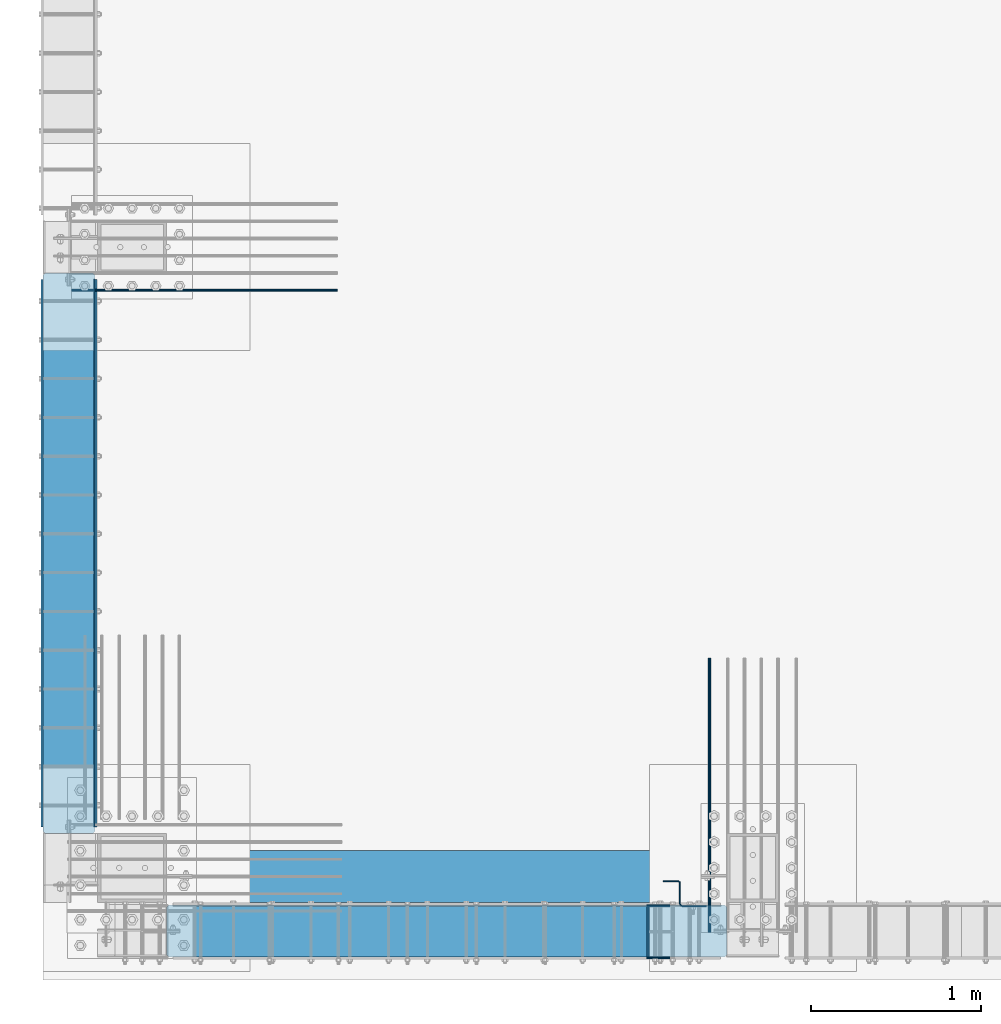
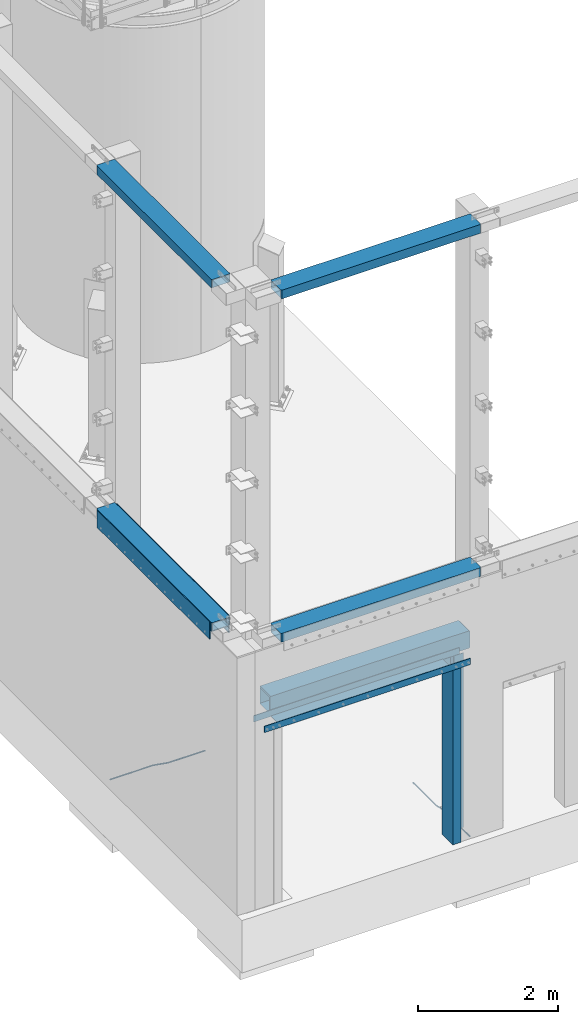
# One storey, part 908 of 1876: 14 beams, 12 elements without a shape of their own.
"""IFC2X3 building model written with IfcOpenShell, lengths in millimetres."""

from ifc_helpers import new_model, si_unit, frame, origin_with_axes, place, context, subcontext, project, spatial, faceted_brep, material, type_object, element, aggregate, save


model = new_model("IFC2X3")

# Units and contexts
model_context = context("Model", 3, precision=1e-05, world=origin_with_axes())
body_context = subcontext(model_context, "Body", "Model", "MODEL_VIEW")
ifc_project = project(units=[si_unit("LENGTHUNIT", "METRE", prefix="MILLI"), si_unit("AREAUNIT", "SQUARE_METRE"), si_unit("VOLUMEUNIT", "CUBIC_METRE"), si_unit("MASSUNIT", "GRAM", prefix="KILO"), si_unit("TIMEUNIT", "SECOND"), si_unit("PLANEANGLEUNIT", "RADIAN"), si_unit("SOLIDANGLEUNIT", "STERADIAN"), si_unit("THERMODYNAMICTEMPERATUREUNIT", "DEGREE_CELSIUS"), si_unit("LUMINOUSINTENSITYUNIT", "LUMEN")], contexts=[model_context])

# Site, building, storey
site_placement = place(None, origin_with_axes())
site = spatial("IfcSite", under=ifc_project, at=site_placement, CompositionType="ELEMENT")
building_placement = place(site_placement, origin_with_axes())
building = spatial("IfcBuilding", under=site, at=building_placement, Name="Undefined", CompositionType="ELEMENT")
storey_placement = place(building_placement, origin_with_axes())
storey = spatial("IfcBuildingStorey", under=building, at=storey_placement, Name="Undefined", CompositionType="ELEMENT", Elevation=0.0)

# Assembly, beam
assembly_1_placement = place(storey_placement, origin_with_axes())
assembly_1 = element("IfcElementAssembly", 1, at=assembly_1_placement, inside=storey, Name="BEAM", AssemblyPlace="NOTDEFINED", PredefinedType="RIGID_FRAME")
ifc_material_1 = material()
beam_type_1 = type_object("IfcBeamType", Name="HSS12X6X1/2", PredefinedType="NOTDEFINED")
beam_1_placement = place(assembly_1_placement, frame((434.974999999999, -25771.475, 10591.8), z_axis=(0.0, 1.0, 0.0), x_axis=(1.0, 0.0, 0.0)))
beam_1 = element("IfcBeam", 2, at=beam_1_placement, type_object=beam_type_1, material=ifc_material_1, Name="BEAM", ObjectType="HSS12X6X1/2", context=body_context, shape_type="Brep", body=[
    faceted_brep([(0.0, -63.5, -139.7), (0.0, -76.2000000000007, -139.699999999812), (0.0, -76.2000000000007, 139.700000000026), (0.0, -63.5, 139.7), (3289.3, 76.2000000000007, -152.400000000001), (3289.3, -76.2000000000007, -152.400000000001), (12.7000000000025, -76.2000000000007, -152.4), (12.7000000000025, 76.2000000000007, -152.4), (3302.0, 63.5, -139.700000000001), (3302.0, 76.2000000000007, -139.700000000004), (3302.0, 76.2000000000007, 139.700000000004), (3302.0, 63.5, 139.700000000001), (3302.0, -63.5, -139.700000000001), (0.0, 63.5, -139.7), (3302.0, -76.2000000000007, -139.700000000004), (3302.0, -76.2000000000007, 139.700000000004), (3289.3, -76.2000000000007, 152.400000000001), (12.6999999999734, -76.2000000000007, 152.4), (0.0, 63.5, 139.7), (12.6999999999734, 76.2000000000007, 152.4), (3302.0, -63.5, 139.700000000001), (3289.3, 76.2000000000007, 152.400000000001)], [[[0, 1, 2, 3]], [[4, 5, 6, 7]], [[8, 9, 10, 11]], [[12, 8, 13, 0]], [[4, 9, 8, 12, 14, 5]], [[1, 6, 5, 14, 15, 16, 17, 2]], [[0, 13, 7, 6, 1]], [[7, 13, 18, 19]], [[8, 11, 18, 13]], [[11, 20, 3, 18]], [[0, 3, 20, 12]], [[14, 12, 20, 15]], [[11, 10, 21, 16, 15, 20]], [[9, 4, 7, 19, 21, 10]], [[16, 21, 19, 17]], [[18, 3, 2, 17, 19]]]),
])
aggregate(assembly_1, [beam_1])

assembly_2_placement = place(storey_placement, origin_with_axes())
assembly_2 = element("IfcElementAssembly", 3, at=assembly_2_placement, inside=storey, Name="BEAM", AssemblyPlace="NOTDEFINED", PredefinedType="RIGID_FRAME")
beam_2_placement = place(assembly_2_placement, frame((-139.700000000005, -25196.8, 10591.8), z_axis=(-1.0, 0.0, 0.0), x_axis=(0.0, 1.0, 0.0)))
beam_2 = element("IfcBeam", 4, at=beam_2_placement, type_object=beam_type_1, material=ifc_material_1, Name="BEAM", ObjectType="HSS12X6X1/2", context=body_context, shape_type="Brep", body=[
    faceted_brep([(0.0, -63.5, -139.7), (0.0, -76.2000000000007, -139.699999999812), (0.0, -76.2000000000007, 139.700000000026), (0.0, -63.5, 139.7), (3302.0, 63.5, -139.700000000001), (3302.0, 76.2000000000007, -139.700000000004), (3302.0, 76.2000000000007, 139.700000000004), (3302.0, 63.5, 139.700000000001), (3289.3, 76.2000000000007, -152.400000000001), (12.7000000000025, 76.2000000000007, -152.4), (12.6999999999734, 76.2000000000007, 152.4), (3289.3, 76.2000000000007, 152.400000000001), (3289.3, -76.2000000000007, -152.400000000001), (12.7000000000025, -76.2000000000007, -152.4), (0.0, 63.5, -139.7), (3302.0, -63.5, -139.700000000001), (3302.0, -76.2000000000007, -139.700000000004), (3302.0, -76.2000000000007, 139.700000000004), (3289.3, -76.2000000000007, 152.400000000001), (12.6999999999734, -76.2000000000007, 152.4), (0.0, 63.5, 139.7), (3302.0, -63.5, 139.700000000001)], [[[0, 1, 2, 3]], [[4, 5, 6, 7]], [[5, 8, 9, 10, 11, 6]], [[8, 12, 13, 9]], [[0, 14, 9, 13, 1]], [[15, 4, 14, 0]], [[8, 5, 4, 15, 16, 12]], [[1, 13, 12, 16, 17, 18, 19, 2]], [[18, 11, 10, 19]], [[20, 3, 2, 19, 10]], [[9, 14, 20, 10]], [[4, 7, 20, 14]], [[7, 21, 3, 20]], [[0, 3, 21, 15]], [[16, 15, 21, 17]], [[7, 6, 11, 18, 17, 21]]]),
])
aggregate(assembly_2, [beam_2])

assembly_3_placement = place(storey_placement, origin_with_axes())
assembly_3 = element("IfcElementAssembly", 5, at=assembly_3_placement, inside=storey, Name="BEAM", AssemblyPlace="NOTDEFINED", PredefinedType="RIGID_FRAME")
beam_3_placement = place(assembly_3_placement, frame((434.974999999999, -25771.475, 4597.4), z_axis=(0.0, 1.0, 0.0), x_axis=(1.0, 0.0, 0.0)))
beam_3 = element("IfcBeam", 6, at=beam_3_placement, type_object=beam_type_1, material=ifc_material_1, Name="BEAM", ObjectType="HSS12X6X1/2", context=body_context, shape_type="Brep", body=[
    faceted_brep([(0.0, -63.5, -139.7), (0.0, -76.2000000000007, -139.699999999812), (0.0, -76.2000000000007, 139.700000000026), (0.0, -63.5, 139.7), (0.0, 76.2000000000007, 139.700000000026), (0.0, 63.5, 139.7), (12.6999999999734, -76.2000000000007, 152.4), (12.6999999999734, 76.2000000000007, 152.4), (0.0, 76.2000000000007, -139.699999999812), (0.0, 63.5, -139.7), (3289.3, 76.2000000000007, -152.400000000001), (3289.3, -76.2000000000007, -152.400000000001), (12.7000000000025, -76.2000000000007, -152.4), (12.7000000000025, 76.2000000000007, -152.4), (3302.0, -63.5, -139.700000000001), (3302.0, 63.5, -139.700000000001), (3302.0, 76.2000000000007, -139.700000000004), (3302.0, -76.2000000000007, -139.700000000004), (3302.0, -76.2000000000007, 139.700000000004), (3289.3, -76.2000000000007, 152.400000000001), (3289.3, 76.2000000000007, 152.400000000001), (3302.0, 76.2000000000007, 139.700000000004), (3302.0, 63.5, 139.700000000001), (3302.0, -63.5, 139.700000000001)], [[[0, 1, 2, 3]], [[4, 5, 3, 2, 6, 7]], [[8, 9, 5, 4]], [[10, 11, 12, 13]], [[0, 9, 8, 13, 12, 1]], [[14, 15, 9, 0]], [[10, 16, 15, 14, 17, 11]], [[1, 12, 11, 17, 18, 19, 6, 2]], [[19, 20, 7, 6]], [[16, 10, 13, 8, 4, 7, 20, 21]], [[15, 16, 21, 22]], [[15, 22, 5, 9]], [[22, 23, 3, 5]], [[0, 3, 23, 14]], [[17, 14, 23, 18]], [[22, 21, 20, 19, 18, 23]]]),
])
aggregate(assembly_3, [beam_3])

assembly_4_placement = place(storey_placement, origin_with_axes())
assembly_4 = element("IfcElementAssembly", 7, at=assembly_4_placement, inside=storey, Name="BEAM", AssemblyPlace="NOTDEFINED", PredefinedType="RIGID_FRAME")
beam_4_placement = place(assembly_4_placement, frame((-139.7, -25196.8, 4597.4), z_axis=(-1.0, 0.0, 0.0), x_axis=(0.0, 1.0, 0.0)))
beam_4 = element("IfcBeam", 8, at=beam_4_placement, type_object=beam_type_1, material=ifc_material_1, Name="BEAM", ObjectType="HSS12X6X1/2", context=body_context, shape_type="Brep", body=[
    faceted_brep([(3302.0, 63.5, 139.700000000001), (3302.0, -63.5, 139.700000000001), (0.0, -63.5, 139.7), (0.0, 63.5, 139.7), (0.0, 76.2000000000007, -139.699999999812), (0.0, 63.5, -139.7), (0.0, 76.2000000000007, 139.700000000026), (0.0, -63.5, -139.7), (12.7000000000025, 76.2000000000007, -152.4), (12.7000000000025, -76.2000000000007, -152.4), (0.0, -76.2000000000007, -139.699999999812), (0.0, -76.2000000000007, 139.700000000026), (12.6999999999734, -76.2000000000007, 152.4), (12.6999999999734, 76.2000000000007, 152.4), (3289.3, -76.2000000000007, 152.400000000001), (3289.3, 76.2000000000007, 152.400000000001), (3302.0, 76.2000000000007, 139.700000000004), (3302.0, -76.2000000000007, 139.700000000004), (3302.0, -76.2000000000007, -139.700000000004), (3302.0, -63.5, -139.700000000001), (3302.0, 63.5, -139.700000000001), (3302.0, 76.2000000000007, -139.700000000004), (3289.3, 76.2000000000007, -152.400000000001), (3289.3, -76.2000000000007, -152.400000000001)], [[[0, 1, 2, 3]], [[4, 5, 3, 6]], [[7, 5, 4, 8, 9, 10]], [[7, 10, 11, 2]], [[6, 3, 2, 11, 12, 13]], [[14, 15, 13, 12]], [[0, 16, 15, 14, 17, 1]], [[18, 19, 1, 17]], [[7, 2, 1, 19]], [[19, 20, 5, 7]], [[20, 0, 3, 5]], [[20, 21, 16, 0]], [[21, 22, 8, 4, 6, 13, 15, 16]], [[22, 23, 9, 8]], [[10, 9, 23, 18, 17, 14, 12, 11]], [[22, 21, 20, 19, 18, 23]]]),
])

assembly_5_placement = place(storey_placement, origin_with_axes())
assembly_5 = element("IfcElementAssembly", 9, at=assembly_5_placement, inside=storey, Name="PLATE", AssemblyPlace="NOTDEFINED", PredefinedType="RIGID_FRAME")
ifc_material_2 = material(Name="STEEL/A36")
beam_type_2 = type_object("IfcBeamType", PredefinedType="NOTDEFINED")
beam_5_placement = place(assembly_5_placement, frame((8.73150000000171, -21932.8999992371, 4432.3), z_axis=(0.0, 0.0, 1.0), x_axis=(0.0, -1.0, 0.0)))
beam_5 = element("IfcBeam", 10, at=beam_5_placement, type_object=beam_type_2, material=ifc_material_2, Name="PLATE", context=body_context, shape_type="Brep", body=[
    faceted_brep([(0.0, 3.969, -38.1000000000004), (0.0, 3.969, 38.1000000000004), (3225.80000076293, 3.969, 38.1000000000004), (3225.80000076293, 3.969, -38.1000000000004), (0.0, -3.969, 38.1000000000004), (3225.80000076293, -3.969, 38.1000000000004), (0.0, -3.969, -38.1000000000004), (3225.80000076293, -3.969, -38.1000000000004)], [[[0, 1, 2, 3]], [[1, 4, 5, 2]], [[4, 6, 7, 5]], [[6, 0, 3, 7]], [[5, 7, 3, 2]], [[6, 4, 1, 0]]]),
])

# Beam
beam_type_3 = type_object("IfcBeamType", PredefinedType="NOTDEFINED")
beam_6_placement = place(assembly_4_placement, frame((-298.450000000009, -21932.9, 4521.2), z_axis=(0.0, 0.0, 1.0), x_axis=(0.0, -1.0, 0.0)))
beam_6 = element("IfcBeam", 11, at=beam_6_placement, type_object=beam_type_3, material=ifc_material_2, Name="PLATE", context=body_context, shape_type="Brep", body=[
    faceted_brep([(0.0, 6.35000000000002, -152.4), (0.0, 6.35000000000002, 152.4), (3225.79999999999, 6.34999999999854, 152.4), (3225.79999999999, 6.34999999999854, -152.4), (0.0, -6.35000000000002, 152.4), (3225.79999999999, -6.34999999999854, 152.4), (0.0, -6.35000000000002, -152.4), (3225.79999999999, -6.34999999999854, -152.4)], [[[0, 1, 2, 3]], [[1, 4, 5, 2]], [[4, 6, 7, 5]], [[6, 0, 3, 7]], [[5, 7, 3, 2]], [[6, 4, 1, 0]]]),
])

aggregate(assembly_4, [beam_6, beam_4])

beam_7_placement = place(assembly_5_placement, frame((19.0500000000002, -21932.8999996185, 4521.2), z_axis=(0.0, 0.0, 1.0), x_axis=(0.0, -1.0, 0.0)))
beam_7 = element("IfcBeam", 12, at=beam_7_placement, type_object=beam_type_3, material=ifc_material_2, Name="PLATE", context=body_context, shape_type="Brep", body=[
    faceted_brep([(0.0, 6.35000000000002, -152.4), (0.0, 6.35000000000002, 152.4), (3225.79999999999, 6.34999999999854, 152.4), (3225.79999999999, 6.34999999999854, -152.4), (0.0, -6.35000000000002, 152.4), (3225.79999999999, -6.34999999999854, 152.4), (0.0, -6.35000000000002, -152.4), (3225.79999999999, -6.34999999999854, -152.4)], [[[0, 1, 2, 3]], [[1, 4, 5, 2]], [[4, 6, 7, 5]], [[6, 0, 3, 7]], [[5, 7, 3, 2]], [[6, 4, 1, 0]]]),
])

aggregate(assembly_5, [beam_5, beam_7])

# Assembly, beam
assembly_6_placement = place(storey_placement, origin_with_axes())
assembly_6 = element("IfcElementAssembly", 13, at=assembly_6_placement, inside=storey, Name="PLATE", AssemblyPlace="NOTDEFINED", PredefinedType="RIGID_FRAME")
ifc_material_3 = material(Name="STEEL/A706-GR.60")
beam_type_4 = type_object("IfcBeamType", Name="5 REBAR", PredefinedType="NOTDEFINED")
beam_8_placement = place(assembly_6_placement, frame((3633.78752441406, -25781.0, -71.4374999999993), z_axis=(-1.0, 0.0, 0.0), x_axis=(0.0, 1.0, 0.0)))
beam_8 = element("IfcBeam", 14, at=beam_8_placement, type_object=beam_type_4, material=ifc_material_3, Name="REBAR", ObjectType="5 REBAR", context=body_context, shape_type="Brep", body=[
    faceted_brep([(0.0, -7.9375, 0.0), (0.0, -5.61266007566822, -5.61266007566883), (760.672013570867, -5.61266007566822, -5.61266007566837), (760.672013570867, -7.9375, 0.0), (0.0, 0.0, -7.9375), (760.672013570867, 0.0, -7.9375), (0.0, 5.61266007566822, -5.61266007566883), (760.672013570867, 5.61266007566822, -5.61266007566837), (0.0, 7.9375, 0.0), (760.672013570867, 7.9375, 0.0), (0.0, 5.61266007566822, 5.61266007566883), (760.672013570867, 5.61266007566822, 5.61266007566837), (0.0, 0.0, 7.9375), (760.672013570867, 0.0, 7.9375), (0.0, -5.61266007566822, 5.61266007566883), (760.672013570867, -5.61266007566822, 5.61266007566837), (762.585579012299, -5.61266007566822, -5.61266007566837), (762.828108499445, -7.9375, 0.0), (762.000061035156, 0.0, -7.9375), (761.414543058014, 5.61266007566822, -5.61266007566837), (761.172013570867, 7.9375, 0.0), (761.414543058014, 5.61266007566822, 5.61266007566837), (762.000061035156, 0.0, 7.9375), (762.585579012299, -5.61266007566822, 5.61266007566837), (764.4579427221, -5.21770838638834, -5.61266007566837), (764.937779698426, -7.49249126611924, 0.0), (763.299513786125, 0.274103293312095, -7.9375), (762.141084850151, 5.76591497301254, -5.61266007566837), (761.661247873824, 8.04069785274343, 0.0), (762.141084850151, 5.76591497301254, 5.61266007566837), (763.299513786125, 0.274103293312095, 7.9375), (764.4579427221, -5.21770838638834, 5.61266007566837), (965.059049427193, 37.096584264048, -5.61266007566837), (965.538886403519, 34.8218013843171, 0.0), (963.900620491218, 42.5883959437484, -7.9375), (962.742191555244, 48.0802076234489, -5.61266007566837), (962.262354578917, 50.3549905031798, 0.0), (962.742191555244, 48.0802076234489, 5.61266007566837), (963.900620491218, 42.5883959437484, 7.9375), (965.059049427193, 37.096584264048, 5.61266007566837), (965.78559121933, 37.2498391613923, -5.61266007566837), (966.028120706476, 34.9249992370605, 0.0), (965.200073242188, 42.8624992370605, -7.9375), (964.614555265045, 48.4751593127288, -5.61266007566837), (964.372025777899, 50.7999992370606, 0.0), (964.614555265045, 48.4751593127288, 5.61266007566837), (965.200073242188, 42.8624992370605, 7.9375), (965.78559121933, 37.2498391613923, 5.61266007566837), (966.528120706476, 37.2498391613923, -5.61266007566837), (966.528120706476, 34.9249992370605, 0.0), (966.528120706476, 42.8624992370605, -7.9375), (966.528120706476, 48.4751593127288, -5.61266007566837), (966.528120706476, 50.7999992370605, 0.0), (966.528120706476, 48.4751593127288, 5.61266007566837), (966.528120706476, 42.8624992370605, 7.9375), (966.528120706476, 37.2498391613923, 5.61266007566837), (1619.25, 37.2498391613923, -5.61266007566837), (1619.25, 34.9249992370605, 0.0), (1619.25, 42.8624992370605, -7.9375), (1619.25, 48.4751593127288, -5.61266007566837), (1619.25, 50.7999992370605, 0.0), (1619.25, 48.4751593127288, 5.61266007566837), (1619.25, 42.8624992370605, 7.9375), (1619.25, 37.2498391613923, 5.61266007566837)], [[[0, 1, 2, 3]], [[1, 4, 5, 2]], [[4, 6, 7, 5]], [[6, 8, 9, 7]], [[8, 10, 11, 9]], [[10, 12, 13, 11]], [[12, 14, 15, 13]], [[14, 0, 3, 15]], [[14, 12, 10, 8, 6, 4, 1, 0]], [[3, 2, 16, 17]], [[2, 5, 18, 16]], [[5, 7, 19, 18]], [[7, 9, 20, 19]], [[9, 11, 21, 20]], [[11, 13, 22, 21]], [[13, 15, 23, 22]], [[15, 3, 17, 23]], [[17, 16, 24, 25]], [[16, 18, 26, 24]], [[18, 19, 27, 26]], [[19, 20, 28, 27]], [[20, 21, 29, 28]], [[21, 22, 30, 29]], [[22, 23, 31, 30]], [[23, 17, 25, 31]], [[25, 24, 32, 33]], [[24, 26, 34, 32]], [[26, 27, 35, 34]], [[27, 28, 36, 35]], [[28, 29, 37, 36]], [[29, 30, 38, 37]], [[30, 31, 39, 38]], [[31, 25, 33, 39]], [[33, 32, 40, 41]], [[32, 34, 42, 40]], [[34, 35, 43, 42]], [[35, 36, 44, 43]], [[36, 37, 45, 44]], [[37, 38, 46, 45]], [[38, 39, 47, 46]], [[39, 33, 41, 47]], [[41, 40, 48, 49]], [[40, 42, 50, 48]], [[42, 43, 51, 50]], [[43, 44, 52, 51]], [[44, 45, 53, 52]], [[45, 46, 54, 53]], [[46, 47, 55, 54]], [[47, 41, 49, 55]], [[49, 48, 56, 57]], [[48, 50, 58, 56]], [[50, 51, 59, 58]], [[51, 52, 60, 59]], [[52, 53, 61, 60]], [[53, 54, 62, 61]], [[54, 55, 63, 62]], [[55, 49, 57, 63]], [[58, 59, 60, 61, 62, 63, 57, 56]]]),
])
aggregate(assembly_6, [beam_8])

assembly_7_placement = place(storey_placement, origin_with_axes())
assembly_7 = element("IfcElementAssembly", 15, at=assembly_7_placement, inside=storey, Name="PLATE", AssemblyPlace="NOTDEFINED", PredefinedType="RIGID_FRAME")
beam_9_placement = place(assembly_7_placement, frame((-123.825012207033, -21996.399983724, -58.7375000000029), z_axis=(0.0, 1.0, 0.0), x_axis=(1.0, 0.0, 0.0)))
beam_9 = element("IfcBeam", 16, at=beam_9_placement, type_object=beam_type_4, material=ifc_material_3, Name="REBAR", ObjectType="5 REBAR", context=body_context, shape_type="Brep", body=[
    faceted_brep([(0.0, -7.9375, 0.0), (0.0, -5.61266007566822, -5.61266007566883), (710.034986674476, -5.61266007566822, -5.61266007566883), (710.034986674476, -7.9375, 0.0), (0.0, 0.0, -7.9375), (710.034986674476, 0.0, -7.9375), (0.0, 5.61266007566822, -5.61266007566883), (710.034986674476, 5.61266007566822, -5.61266007566883), (0.0, 7.9375, 0.0), (710.034986674476, 7.9375, 0.0), (0.0, 5.61266007566822, 5.61266007566883), (710.034986674476, 5.61266007566822, 5.61266007566883), (0.0, 0.0, 7.9375), (710.034986674476, 0.0, 7.9375), (0.0, -5.61266007566822, 5.61266007566883), (710.034986674476, -5.61266007566822, 5.61266007566883), (711.670256270764, -5.61266007566822, -5.61266007566883), (711.865037739587, -7.9375, 0.0), (711.200012207031, 0.0, -7.9375), (710.729768143299, 5.61266007566822, -5.61266007566883), (710.534986674476, 7.9375, 0.0), (710.729768143299, 5.61266007566822, 5.61266007566883), (711.200012207031, 0.0, 7.9375), (711.670256270764, -5.61266007566822, 5.61266007566883), (713.282728188834, -5.34055537895146, -5.61266007566883), (713.669575632193, -7.63298416286913, 0.0), (712.34879584451, 0.193857281957023, -7.9375), (711.414863500185, 5.72826994286551, -5.61266007566883), (711.028016056827, 8.02069872678318, 0.0), (711.414863500185, 5.72826994286551, 5.61266007566883), (712.34879584451, 0.193857281957023, 7.9375), (713.282728188834, -5.34055537895146, 5.61266007566883), (964.985099878721, 37.1342292941951, -5.61266007566883), (965.371947322079, 34.8418005102774, 0.0), (964.051167534397, 42.6686419551035, -7.9375), (963.117235190072, 48.203054616012, -5.61266007566883), (962.730387746714, 50.4954833999297, 0.0), (963.117235190072, 48.203054616012, 5.61266007566883), (964.051167534397, 42.6686419551035, 7.9375), (964.985099878721, 37.1342292941951, 5.61266007566883), (965.670195235607, 37.2498391613923, -5.61266007566883), (965.864976704431, 34.9249992370606, 0.0), (965.199951171875, 42.8624992370605, -7.9375), (964.729707108143, 48.4751593127287, -5.61266007566883), (964.534925639319, 50.7999992370605, 0.0), (964.729707108143, 48.4751593127287, 5.61266007566883), (965.199951171875, 42.8624992370605, 7.9375), (965.670195235607, 37.2498391613923, 5.61266007566883), (966.36497670443, 37.2498391613923, -5.61266007566883), (966.36497670443, 34.9249992370605, 0.0), (966.36497670443, 42.8624992370605, -7.9375), (966.36497670443, 48.4751593127288, -5.61266007566883), (966.36497670443, 50.7999992370605, 0.0), (966.36497670443, 48.4751593127288, 5.61266007566883), (966.36497670443, 42.8624992370605, 7.9375), (966.36497670443, 37.2498391613923, 5.61266007566883), (1566.86254882812, 37.2498391613923, -5.61266007566883), (1566.86254882812, 34.9249992370605, 0.0), (1566.86254882812, 42.8624992370605, -7.9375), (1566.86254882812, 48.4751593127288, -5.61266007566883), (1566.86254882812, 50.7999992370605, 0.0), (1566.86254882812, 48.4751593127288, 5.61266007566883), (1566.86254882812, 42.8624992370605, 7.9375), (1566.86254882812, 37.2498391613923, 5.61266007566883)], [[[0, 1, 2, 3]], [[1, 4, 5, 2]], [[4, 6, 7, 5]], [[6, 8, 9, 7]], [[8, 10, 11, 9]], [[10, 12, 13, 11]], [[12, 14, 15, 13]], [[14, 0, 3, 15]], [[14, 12, 10, 8, 6, 4, 1, 0]], [[3, 2, 16, 17]], [[2, 5, 18, 16]], [[5, 7, 19, 18]], [[7, 9, 20, 19]], [[9, 11, 21, 20]], [[11, 13, 22, 21]], [[13, 15, 23, 22]], [[15, 3, 17, 23]], [[17, 16, 24, 25]], [[16, 18, 26, 24]], [[18, 19, 27, 26]], [[19, 20, 28, 27]], [[20, 21, 29, 28]], [[21, 22, 30, 29]], [[22, 23, 31, 30]], [[23, 17, 25, 31]], [[25, 24, 32, 33]], [[24, 26, 34, 32]], [[26, 27, 35, 34]], [[27, 28, 36, 35]], [[28, 29, 37, 36]], [[29, 30, 38, 37]], [[30, 31, 39, 38]], [[31, 25, 33, 39]], [[33, 32, 40, 41]], [[32, 34, 42, 40]], [[34, 35, 43, 42]], [[35, 36, 44, 43]], [[36, 37, 45, 44]], [[37, 38, 46, 45]], [[38, 39, 47, 46]], [[39, 33, 41, 47]], [[41, 40, 48, 49]], [[40, 42, 50, 48]], [[42, 43, 51, 50]], [[43, 44, 52, 51]], [[44, 45, 53, 52]], [[45, 46, 54, 53]], [[46, 47, 55, 54]], [[47, 41, 49, 55]], [[49, 48, 56, 57]], [[48, 50, 58, 56]], [[50, 51, 59, 58]], [[51, 52, 60, 59]], [[52, 53, 61, 60]], [[53, 54, 62, 61]], [[54, 55, 63, 62]], [[55, 49, 57, 63]], [[58, 59, 60, 61, 62, 63, 57, 56]]]),
])
aggregate(assembly_7, [beam_9])

assembly_8_placement = place(storey_placement, origin_with_axes())
assembly_8 = element("IfcElementAssembly", 17, at=assembly_8_placement, inside=storey, Name="BENT PLATE", AssemblyPlace="NOTDEFINED", PredefinedType="RIGID_FRAME")
beam_type_5 = type_object("IfcBeamType", PredefinedType="NOTDEFINED")
beam_10_placement = place(assembly_8_placement, frame((1854.19999954951, -25622.2500061036, 3159.12500000004), z_axis=(1.0, 0.0, 0.0), x_axis=(0.0, 0.0, -1.0)))
beam_10 = element("IfcBeam", 18, at=beam_10_placement, type_object=beam_type_5, material=ifc_material_2, Name="BENT PLATE", context=body_context, shape_type="Brep", body=[
    faceted_brep([(111.124998474122, -4.76250610359057, -1422.40003657346), (101.599998474122, -4.76250000000073, -1422.40003662109), (101.599998474122, -4.76250000000073, -1701.8), (111.124998474122, -4.76250000000073, -1701.8), (111.124998474122, -301.624987792969, -1422.40003657346), (101.599998474122, -301.624987792969, -1422.40003662109), (111.124998474122, -301.624987792969, -1701.8), (101.599998474122, -301.624987792969, -1701.8), (0.0, -4.76250000000073, -1701.8), (0.0, 4.76250000000073, -1701.8), (111.124998474122, 4.76250000000073, -1701.8), (0.0, 4.76250000000073, 1701.8), (111.124998474122, 4.76250000000073, 1701.8), (0.0, -4.76250000000073, -1422.40003712909), (0.0, -4.76250000000073, 1422.40004877062), (0.0, -4.76250000000073, 1701.8), (101.599998474122, -4.76250000000073, 1701.8), (111.124998474122, -4.76250000000073, 1701.8), (101.599998474122, -4.76250000000073, 1422.40004927861), (111.124998474122, -4.76249389641816, 1422.40004932624), (101.599998474122, -301.624987792969, 1422.40004927862), (111.124998474122, -301.624981689387, 1422.40004932624), (111.124998474122, -301.624981689387, 1701.80001270515), (101.599998474122, -301.624987792969, 1701.8), (0.0, -301.624987792969, 1701.8), (0.0, -311.149987792971, 1701.8), (111.124998474122, -311.149987792971, 1701.8), (111.124998474122, -311.149987792971, -1701.8), (0.0, -311.149987792971, -1701.8), (0.0, -301.624987792969, 1422.40004877062), (0.0, -301.624987792969, -1422.40003712909), (0.0, -301.624987792969, -1701.8)], [[[0, 1, 2, 3]], [[4, 5, 1, 0]], [[6, 7, 5, 4]], [[8, 9, 10, 3, 2]], [[9, 11, 12, 10]], [[8, 13, 14, 15, 11, 9]], [[12, 11, 15, 16, 17]], [[17, 16, 18, 19]], [[15, 14, 13, 8, 2, 1, 18, 16]], [[20, 18, 1, 5]], [[19, 18, 20, 21]], [[22, 21, 20, 23]], [[24, 25, 26, 22, 23]], [[27, 26, 25, 28]], [[24, 29, 30, 31, 28, 25]], [[23, 20, 5, 7, 31, 30, 29, 24]], [[27, 28, 31, 7, 6]], [[3, 10, 12, 17, 19, 21, 22, 26, 27, 6, 4, 0]]]),
])
aggregate(assembly_8, [beam_10])

assembly_9_placement = place(storey_placement, origin_with_axes())
assembly_9 = element("IfcElementAssembly", 19, at=assembly_9_placement, inside=storey, Name="BENT PLATE", AssemblyPlace="NOTDEFINED", PredefinedType="RIGID_FRAME")
beam_type_6 = type_object("IfcBeamType", PredefinedType="NOTDEFINED")
beam_11_placement = place(assembly_9_placement, frame((3614.73799890872, -25625.4250147517, 1524.0), z_axis=(0.0, 0.0, 1.0), x_axis=(-1.0, 0.0, 0.0)))
beam_11 = element("IfcBeam", 20, at=beam_11_placement, type_object=beam_type_6, material=ifc_material_2, Name="BENT PLATE", context=body_context, shape_type="Brep", body=[
    faceted_brep([(-9.88620740827173e-10, 3.17500000000291, -1524.0), (-9.88620740827173e-10, 3.17500000000291, 1524.0), (139.699995674332, 3.17500000233849, 1524.0), (139.699995674332, 3.17500000233849, -1524.0), (9.877112461254e-10, -3.17499999999563, 1524.0), (9.877112461254e-10, -3.17499999999563, -1524.0), (139.699995674433, -3.17499999766005, -1524.0), (139.699995674433, -3.17499999766005, 1524.0), (149.224994891685, 0.622784366969427, 1524.0), (149.224994891685, 0.622784366969427, -1524.0), (146.049995120879, -4.87647707938777, -1524.0), (146.049995120879, -4.87647707938777, 1524.0), (150.698517608313, -9.52499898567839, -1524.0), (150.698517608313, -9.52499898567839, 1524.0), (156.197778657743, -6.34999852737201, 1524.0), (156.197778657743, -6.34999852737201, -1524.0), (152.399995483898, -15.8749982194149, -1524.0), (152.399995483898, -15.8749982194149, 1524.0), (158.749995483898, -15.8749974256571, 1524.0), (158.749995483899, -15.8749974256571, -1524.0), (158.750010565149, -136.52499865716, 1524.0), (158.750010565148, -136.52499865716, -1524.0), (152.400010565148, -136.524999450916, -1524.0), (152.400010565148, -136.524999450916, 1524.0), (159.600749622438, -139.69999845545, 1524.0), (159.600749622438, -139.69999845545, -1524.0), (154.101488705282, -142.874999142861, -1524.0), (154.101488705282, -142.874999142861, 1524.0), (158.750011844602, -147.523521120045, -1524.0), (158.750011844602, -147.523521120045, 1524.0), (161.925011157192, -142.024259409134, 1524.0), (161.925011157192, -142.024259409134, -1524.0), (165.100011961915, -149.224997672669, -1524.0), (165.100011961915, -149.224997672669, 1524.0), (165.100011168165, -142.87499767267, 1524.0), (165.100011168165, -142.87499767267, -1524.0), (254.000017462373, -142.874986560088, 1524.0), (254.000017462373, -142.874986560088, -1524.0), (254.000018256123, -149.224986560088, 1524.0), (254.000018256123, -149.224986560088, -1524.0)], [[[0, 1, 2, 3]], [[4, 5, 6, 7]], [[5, 4, 1, 0]], [[3, 2, 8, 9]], [[7, 6, 10, 11]], [[10, 12, 13, 11]], [[8, 14, 15, 9]], [[12, 16, 17, 13]], [[14, 18, 19, 15]], [[19, 18, 20, 21]], [[17, 16, 22, 23]], [[21, 20, 24, 25]], [[23, 22, 26, 27]], [[26, 28, 29, 27]], [[24, 30, 31, 25]], [[28, 32, 33, 29]], [[30, 34, 35, 31]], [[35, 34, 36, 37]], [[34, 30, 24, 20, 18, 14, 8, 2, 1, 4, 7, 11, 13, 17, 23, 27, 29, 33, 38, 36]], [[33, 32, 39, 38]], [[32, 28, 26, 22, 16, 12, 10, 6, 5, 0, 3, 9, 15, 19, 21, 25, 31, 35, 37, 39]], [[38, 39, 37, 36]]]),
])
aggregate(assembly_9, [beam_11])

assembly_10_placement = place(storey_placement, origin_with_axes())
assembly_10 = element("IfcElementAssembly", 21, at=assembly_10_placement, inside=storey, Name="BEAM", AssemblyPlace="NOTDEFINED", PredefinedType="REINFORCEMENT_UNIT")
ifc_material_4 = material(Name="CONCRETE/5000")
beam_type_7 = type_object("IfcBeamType", PredefinedType="NOTDEFINED")
beam_12_placement = place(assembly_10_placement, frame((3398.83799839303, -25926.256, 1524.0), z_axis=(0.0, 0.0, 1.0), x_axis=(-1.0, 0.0, 0.0)))
beam_12 = element("IfcBeam", 22, at=beam_12_placement, type_object=beam_type_7, material=ifc_material_4, Name="BEAM", context=body_context, shape_type="Brep", body=[
    faceted_brep([(1.60071067512035e-10, -2.38100000000122, -1524.0), (1.60071067512035e-10, -2.38100000000122, 1524.0), (-1.60071067512035e-10, 2.38099999999758, 1524.0), (-1.60071067512035e-10, 2.38099999999758, -1524.0), (126.999998724466, 2.3810000085341, 1524.0), (126.999998724466, 2.3810000085341, -1524.0), (122.237998962564, -2.38099999178485, -1524.0), (122.237998962564, -2.38099999178485, 1524.0), (127.000013964417, -302.417987546485, 1524.0), (127.000013964417, -302.417987546485, -1524.0), (122.238013726317, -297.655987784585, -1524.0), (122.238013726317, -297.655987784585, 1524.0), (1.50022988236742e-05, -302.417993896486, 1524.0), (1.50022988236742e-05, -302.417993896486, -1524.0), (1.47641985677183e-05, -297.655993896486, 1524.0), (1.47641985677183e-05, -297.655993896486, -1524.0)], [[[0, 1, 2, 3]], [[3, 2, 4, 5]], [[1, 0, 6, 7]], [[5, 4, 8, 9]], [[7, 6, 10, 11]], [[9, 8, 12, 13]], [[8, 4, 2, 1, 7, 11, 14, 12]], [[11, 10, 15, 14]], [[10, 6, 0, 3, 5, 9, 13, 15]], [[14, 15, 13, 12]]]),
])
aggregate(assembly_10, [beam_12])

assembly_11_placement = place(storey_placement, origin_with_axes())
assembly_11 = element("IfcElementAssembly", 23, at=assembly_11_placement, inside=storey, Name="BENT PLATE", AssemblyPlace="NOTDEFINED", PredefinedType="RIGID_FRAME")
beam_type_8 = type_object("IfcBeamType", PredefinedType="NOTDEFINED")
beam_13_placement = place(assembly_11_placement, frame((3398.83799827414, -25931.812, 1524.0), z_axis=(0.0, 0.0, 1.0), x_axis=(-1.0, 0.0, 0.0)))
beam_13 = element("IfcBeam", 24, at=beam_13_placement, type_object=beam_type_8, material=ifc_material_2, Name="BENT PLATE", context=body_context, shape_type="Brep", body=[
    faceted_brep([(9.877112461254e-10, -3.17499999999563, -1524.0), (9.877112461254e-10, -3.17499999999563, 1524.0), (-9.88620740827173e-10, 3.17500000000291, 1524.0), (-9.88620740827173e-10, 3.17500000000291, -1524.0), (133.349999999999, 3.17499999999927, 1524.0), (133.349999999999, 3.17499999999927, -1524.0), (126.999999999999, -3.17499999999927, -1524.0), (126.999999999999, -3.17499999999927, 1524.0), (133.349999999999, -315.911474609373, 1524.0), (133.349999999999, -315.911474609373, -1524.0), (126.999999999999, -309.561474609374, -1524.0), (126.999999999999, -309.561474609374, 1524.0), (-2.37773747358005e-07, -315.911474609373, 1524.0), (-2.37773747358005e-07, -315.911474609373, -1524.0), (-2.37773747358005e-07, -309.561474609374, 1524.0), (-2.37773747358005e-07, -309.561474609374, -1524.0)], [[[0, 1, 2, 3]], [[3, 2, 4, 5]], [[1, 0, 6, 7]], [[5, 4, 8, 9]], [[7, 6, 10, 11]], [[9, 8, 12, 13]], [[8, 4, 2, 1, 7, 11, 14, 12]], [[11, 10, 15, 14]], [[10, 6, 0, 3, 5, 9, 13, 15]], [[14, 15, 13, 12]]]),
])
aggregate(assembly_11, [beam_13])

assembly_12_placement = place(storey_placement, origin_with_axes())
assembly_12 = element("IfcElementAssembly", 25, at=assembly_12_placement, inside=storey, Name="BEAM", AssemblyPlace="NOTDEFINED", PredefinedType="RIGID_FRAME")
beam_type_9 = type_object("IfcBeamType", Name="HSS12X12X1/2", PredefinedType="NOTDEFINED")
beam_14_placement = place(assembly_12_placement, frame((434.975, -25450.8, 3225.8), z_axis=(0.0, 1.0, 0.0), x_axis=(1.0, 0.0, 0.0)))
beam_14 = element("IfcBeam", 26, at=beam_14_placement, type_object=beam_type_9, material=ifc_material_1, Name="BEAM", ObjectType="HSS12X12X1/2", context=body_context, shape_type="Brep", body=[
    faceted_brep([(0.0, 139.7, -139.700000000001), (0.0, 139.700000000001, -152.400000000001), (0.0, -139.699999999993, -152.400000000001), (0.0, -139.7, -139.700000000001), (3302.0, -139.7, -139.700000000001), (3302.0, 139.7, -139.700000000001), (3302.0, -139.699999999988, -152.400000000001), (3302.0, 139.699999999988, -152.400000000001), (12.6999999999994, 152.4, -152.400000000001), (3289.29999999999, 152.4, -152.400000000001), (3289.29999999999, -152.4, -152.400000000001), (12.7000000000066, -152.4, -152.400000000001), (3289.29999999999, 152.4, 152.400000000001), (3302.0, 139.7, 139.700000000001), (3289.29999999999, -152.4, 152.400000000001), (3302.0, -139.7, 139.700000000001), (12.7000000000066, -152.4, 152.400000000001), (0.0, -139.7, 139.700000000001), (0.0, 139.7, 139.700000000001), (12.6999999999994, 152.4, 152.400000000001)], [[[0, 1, 2, 3]], [[0, 3, 4, 5]], [[4, 6, 7, 5]], [[1, 8, 9, 7, 6, 10, 11, 2]], [[5, 7, 9, 12, 13]], [[12, 14, 15, 13]], [[10, 6, 4, 15, 14]], [[10, 14, 16, 11]], [[3, 2, 11, 16, 17]], [[15, 4, 3, 17]], [[13, 15, 17, 18]], [[5, 13, 18, 0]], [[8, 1, 0, 18, 19]], [[12, 9, 8, 19]], [[14, 12, 19, 16]], [[18, 17, 16, 19]]]),
])
aggregate(assembly_12, [beam_14])

save(model, "model.ifc")
